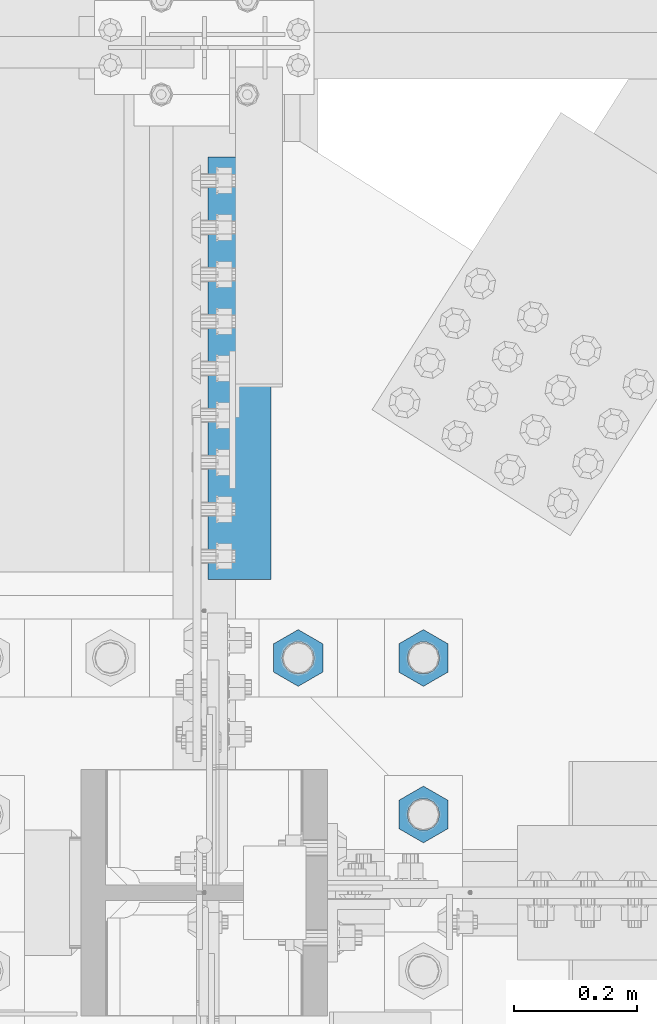
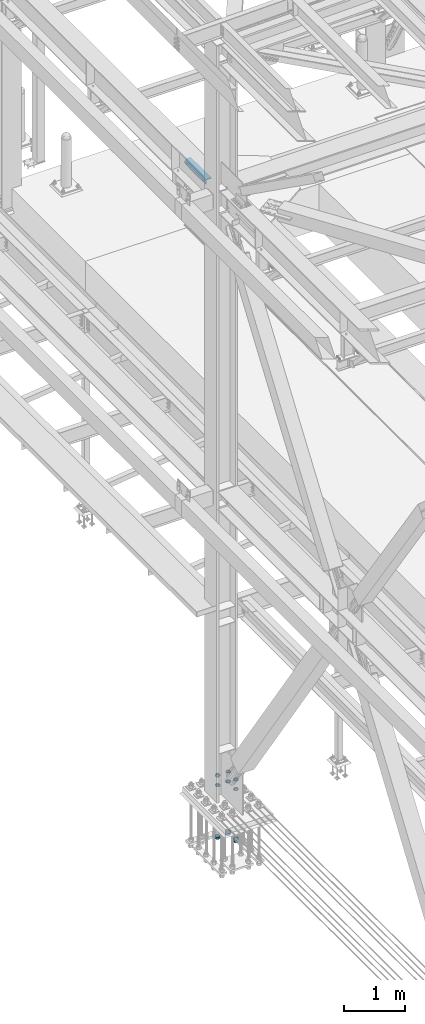
# One storey, part 2388 of 3843: 12 beams, 2 elements without a shape of their own.
"""IFC2X3 building model written with IfcOpenShell, lengths in millimetres."""

from ifc_helpers import new_model, si_unit, frame, origin_with_axes, place, context, subcontext, project, spatial, faceted_brep, material, type_object, element, aggregate, save


model = new_model("IFC2X3")

# Units and contexts
model_context = context("Model", 3, precision=1e-05, world=origin_with_axes())
body_context = subcontext(model_context, "Body", "Model", "MODEL_VIEW")
ifc_project = project(units=[si_unit("LENGTHUNIT", "METRE", prefix="MILLI"), si_unit("AREAUNIT", "SQUARE_METRE"), si_unit("VOLUMEUNIT", "CUBIC_METRE"), si_unit("MASSUNIT", "GRAM", prefix="KILO"), si_unit("TIMEUNIT", "SECOND"), si_unit("PLANEANGLEUNIT", "RADIAN"), si_unit("SOLIDANGLEUNIT", "STERADIAN"), si_unit("THERMODYNAMICTEMPERATUREUNIT", "DEGREE_CELSIUS"), si_unit("LUMINOUSINTENSITYUNIT", "LUMEN")], contexts=[model_context])

# Site, building, storey
site_placement = place(None, origin_with_axes())
site = spatial("IfcSite", under=ifc_project, at=site_placement, CompositionType="ELEMENT")
building_placement = place(site_placement, origin_with_axes())
building = spatial("IfcBuilding", under=site, at=building_placement, Name="Undefined", CompositionType="ELEMENT")
storey_placement = place(building_placement, origin_with_axes())
storey = spatial("IfcBuildingStorey", under=building, at=storey_placement, Name="Undefined", CompositionType="ELEMENT", Elevation=0.0)

# Assembly, beams
assembly_1_placement = place(storey_placement, origin_with_axes())
assembly_1 = element("IfcElementAssembly", 1, at=assembly_1_placement, inside=storey, Name="TEMPLATE", AssemblyPlace="NOTDEFINED", PredefinedType="RIGID_FRAME")
ifc_material = material(Name="STEEL/A572-50")
beam_type_1 = type_object("IfcBeamType", Name="2_HALF_NUT", PredefinedType="NOTDEFINED")
beam_1_placement = place(assembly_1_placement, frame((36931.6, 75755.5, 30060.9), z_axis=(1.0, 0.0, 0.0), x_axis=(0.0, 0.0, -1.0)))
beam_1 = element("IfcBeam", 2, at=beam_1_placement, type_object=beam_type_1, material=ifc_material, Name="NUT", ObjectType="2_HALF_NUT", context=body_context, shape_type="Brep", body=[
    faceted_brep([(0.0, -46.0369987487793, 0.0), (0.0, -23.0184993743896, -39.869213104248), (25.4000000000015, -23.0184993743896, -39.869213104248), (25.4000000000015, -46.0369987487793, 0.0), (0.0, 23.0184993743896, -39.869213104248), (25.4000000000015, 23.0184993743896, -39.869213104248), (0.0, 46.0369987487793, 0.0), (25.4000000000015, 46.0369987487793, 0.0), (0.0, 23.0184993743896, 39.869213104248), (25.4000000000015, 23.0184993743896, 39.869213104248), (0.0, -23.0184993743896, 39.869213104248), (25.4000000000015, -23.0184993743896, 39.869213104248), (0.0, 0.0, 26.1940002441406), (0.0, 11.3650617044477, 23.5999013092805), (25.4000000000015, 11.3650617044477, 23.5999013092805), (25.4000000000015, 0.0, 26.1940002441406), (0.0, 20.4791109456419, 16.3316083006721), (25.4000000000015, 20.4791109456419, 16.3316083006721), (0.0, 25.5370200498292, 5.82867859874386), (25.4000000000015, 25.5370200498292, 5.82867859874386), (0.0, 25.5370200498292, -5.82867859874386), (25.4000000000015, 25.5370200498292, -5.82867859874386), (0.0, 20.4791109456419, -16.3316083006721), (25.4000000000015, 20.4791109456419, -16.3316083006721), (0.0, 11.3650617044477, -23.5999013092805), (25.4000000000015, 11.3650617044477, -23.5999013092805), (0.0, 0.0, -26.1940002441406), (25.4000000000015, 0.0, -26.1940002441406), (0.0, -11.3650617044477, -23.5999013092805), (25.4000000000015, -11.3650617044477, -23.5999013092805), (0.0, -20.4791109456419, -16.3316083006721), (25.4000000000015, -20.4791109456419, -16.3316083006721), (0.0, -25.5370200498292, -5.82867859874386), (25.4000000000015, -25.5370200498292, -5.82867859874386), (0.0, -25.5370200498292, 5.82867859874386), (25.4000000000015, -25.5370200498292, 5.82867859874386), (0.0, -20.4791109456419, 16.3316083006721), (25.4000000000015, -20.4791109456419, 16.3316083006721), (0.0, -11.3650617044477, 23.5999013092805), (25.4000000000015, -11.3650617044477, 23.5999013092805)], [[[0, 1, 2, 3]], [[1, 4, 5, 2]], [[4, 6, 7, 5]], [[6, 8, 9, 7]], [[8, 10, 11, 9]], [[10, 0, 3, 11]], [[12, 13, 14, 15]], [[13, 16, 17, 14]], [[16, 18, 19, 17]], [[18, 20, 21, 19]], [[20, 22, 23, 21]], [[22, 24, 25, 23]], [[24, 26, 27, 25]], [[26, 28, 29, 27]], [[28, 30, 31, 29]], [[30, 32, 33, 31]], [[32, 34, 35, 33]], [[34, 36, 37, 35]], [[36, 38, 39, 37]], [[38, 12, 15, 39]], [[5, 7, 9, 11, 3, 2], [17, 19, 21, 23, 25, 27, 29, 31, 33, 35, 37, 39, 15, 14]], [[10, 8, 6, 4, 1, 0], [38, 36, 34, 32, 30, 28, 26, 24, 22, 20, 18, 16, 13, 12]]]),
])
beam_2_placement = place(assembly_1_placement, frame((36931.6, 76009.5, 30060.9), z_axis=(1.0, 0.0, 0.0), x_axis=(0.0, 0.0, -1.0)))
beam_2 = element("IfcBeam", 3, at=beam_2_placement, type_object=beam_type_1, material=ifc_material, Name="NUT", ObjectType="2_HALF_NUT", context=body_context, shape_type="Brep", body=[
    faceted_brep([(0.0, -46.0369987487793, 0.0), (0.0, -23.0184993743896, -39.869213104248), (25.4000000000015, -23.0184993743896, -39.869213104248), (25.4000000000015, -46.0369987487793, 0.0), (0.0, 23.0184993743896, -39.869213104248), (25.4000000000015, 23.0184993743896, -39.869213104248), (0.0, 46.0369987487793, 0.0), (25.4000000000015, 46.0369987487793, 0.0), (0.0, 23.0184993743896, 39.869213104248), (25.4000000000015, 23.0184993743896, 39.869213104248), (0.0, -23.0184993743896, 39.869213104248), (25.4000000000015, -23.0184993743896, 39.869213104248), (0.0, 0.0, 26.1940002441406), (0.0, 11.3650617044477, 23.5999013092805), (25.4000000000015, 11.3650617044477, 23.5999013092805), (25.4000000000015, 0.0, 26.1940002441406), (0.0, 20.4791109456419, 16.3316083006721), (25.4000000000015, 20.4791109456419, 16.3316083006721), (0.0, 25.5370200498292, 5.82867859874386), (25.4000000000015, 25.5370200498292, 5.82867859874386), (0.0, 25.5370200498292, -5.82867859874386), (25.4000000000015, 25.5370200498292, -5.82867859874386), (0.0, 20.4791109456419, -16.3316083006721), (25.4000000000015, 20.4791109456419, -16.3316083006721), (0.0, 11.3650617044477, -23.5999013092805), (25.4000000000015, 11.3650617044477, -23.5999013092805), (0.0, 0.0, -26.1940002441406), (25.4000000000015, 0.0, -26.1940002441406), (0.0, -11.3650617044477, -23.5999013092805), (25.4000000000015, -11.3650617044477, -23.5999013092805), (0.0, -20.4791109456419, -16.3316083006721), (25.4000000000015, -20.4791109456419, -16.3316083006721), (0.0, -25.5370200498292, -5.82867859874386), (25.4000000000015, -25.5370200498292, -5.82867859874386), (0.0, -25.5370200498292, 5.82867859874386), (25.4000000000015, -25.5370200498292, 5.82867859874386), (0.0, -20.4791109456419, 16.3316083006721), (25.4000000000015, -20.4791109456419, 16.3316083006721), (0.0, -11.3650617044477, 23.5999013092805), (25.4000000000015, -11.3650617044477, 23.5999013092805)], [[[0, 1, 2, 3]], [[1, 4, 5, 2]], [[4, 6, 7, 5]], [[6, 8, 9, 7]], [[8, 10, 11, 9]], [[10, 0, 3, 11]], [[12, 13, 14, 15]], [[13, 16, 17, 14]], [[16, 18, 19, 17]], [[18, 20, 21, 19]], [[20, 22, 23, 21]], [[22, 24, 25, 23]], [[24, 26, 27, 25]], [[26, 28, 29, 27]], [[28, 30, 31, 29]], [[30, 32, 33, 31]], [[32, 34, 35, 33]], [[34, 36, 37, 35]], [[36, 38, 39, 37]], [[38, 12, 15, 39]], [[5, 7, 9, 11, 3, 2], [17, 19, 21, 23, 25, 27, 29, 31, 33, 35, 37, 39, 15, 14]], [[10, 8, 6, 4, 1, 0], [38, 36, 34, 32, 30, 28, 26, 24, 22, 20, 18, 16, 13, 12]]]),
])
beam_3_placement = place(assembly_1_placement, frame((36728.4, 76009.5, 30060.9), z_axis=(1.0, 0.0, 0.0), x_axis=(0.0, 0.0, -1.0)))
beam_3 = element("IfcBeam", 4, at=beam_3_placement, type_object=beam_type_1, material=ifc_material, Name="NUT", ObjectType="2_HALF_NUT", context=body_context, shape_type="Brep", body=[
    faceted_brep([(0.0, -46.0369987487793, 0.0), (0.0, -23.0184993743896, -39.869213104248), (25.4000000000015, -23.0184993743896, -39.869213104248), (25.4000000000015, -46.0369987487793, 0.0), (0.0, 23.0184993743896, -39.869213104248), (25.4000000000015, 23.0184993743896, -39.869213104248), (0.0, 46.0369987487793, 0.0), (25.4000000000015, 46.0369987487793, 0.0), (0.0, 23.0184993743896, 39.869213104248), (25.4000000000015, 23.0184993743896, 39.869213104248), (0.0, -23.0184993743896, 39.869213104248), (25.4000000000015, -23.0184993743896, 39.869213104248), (0.0, 0.0, 26.1940002441406), (0.0, 11.3650617044477, 23.5999013092805), (25.4000000000015, 11.3650617044477, 23.5999013092805), (25.4000000000015, 0.0, 26.1940002441406), (0.0, 20.4791109456419, 16.3316083006721), (25.4000000000015, 20.4791109456419, 16.3316083006721), (0.0, 25.5370200498292, 5.82867859874386), (25.4000000000015, 25.5370200498292, 5.82867859874386), (0.0, 25.5370200498292, -5.82867859874386), (25.4000000000015, 25.5370200498292, -5.82867859874386), (0.0, 20.4791109456419, -16.3316083006721), (25.4000000000015, 20.4791109456419, -16.3316083006721), (0.0, 11.3650617044477, -23.5999013092805), (25.4000000000015, 11.3650617044477, -23.5999013092805), (0.0, 0.0, -26.1940002441406), (25.4000000000015, 0.0, -26.1940002441406), (0.0, -11.3650617044477, -23.5999013092805), (25.4000000000015, -11.3650617044477, -23.5999013092805), (0.0, -20.4791109456419, -16.3316083006721), (25.4000000000015, -20.4791109456419, -16.3316083006721), (0.0, -25.5370200498292, -5.82867859874386), (25.4000000000015, -25.5370200498292, -5.82867859874386), (0.0, -25.5370200498292, 5.82867859874386), (25.4000000000015, -25.5370200498292, 5.82867859874386), (0.0, -20.4791109456419, 16.3316083006721), (25.4000000000015, -20.4791109456419, 16.3316083006721), (0.0, -11.3650617044477, 23.5999013092805), (25.4000000000015, -11.3650617044477, 23.5999013092805)], [[[0, 1, 2, 3]], [[1, 4, 5, 2]], [[4, 6, 7, 5]], [[6, 8, 9, 7]], [[8, 10, 11, 9]], [[10, 0, 3, 11]], [[12, 13, 14, 15]], [[13, 16, 17, 14]], [[16, 18, 19, 17]], [[18, 20, 21, 19]], [[20, 22, 23, 21]], [[22, 24, 25, 23]], [[24, 26, 27, 25]], [[26, 28, 29, 27]], [[28, 30, 31, 29]], [[30, 32, 33, 31]], [[32, 34, 35, 33]], [[34, 36, 37, 35]], [[36, 38, 39, 37]], [[38, 12, 15, 39]], [[5, 7, 9, 11, 3, 2], [17, 19, 21, 23, 25, 27, 29, 31, 33, 35, 37, 39, 15, 14]], [[10, 8, 6, 4, 1, 0], [38, 36, 34, 32, 30, 28, 26, 24, 22, 20, 18, 16, 13, 12]]]),
])
beam_4_placement = place(assembly_1_placement, frame((36931.6, 75755.5, 29070.3), z_axis=(-1.0, 0.0, 0.0), x_axis=(0.0, 0.0, -1.0)))
beam_4 = element("IfcBeam", 5, at=beam_4_placement, type_object=beam_type_1, material=ifc_material, Name="NUT", ObjectType="2_HALF_NUT", context=body_context, shape_type="Brep", body=[
    faceted_brep([(0.0, -46.0369987487793, 0.0), (0.0, -23.0184993743896, -39.869213104248), (25.4000000000015, -23.0184993743896, -39.869213104248), (25.4000000000015, -46.0369987487793, 0.0), (0.0, 23.0184993743896, -39.869213104248), (25.4000000000015, 23.0184993743896, -39.869213104248), (0.0, 46.0369987487793, 0.0), (25.4000000000015, 46.0369987487793, 0.0), (0.0, 23.0184993743896, 39.869213104248), (25.4000000000015, 23.0184993743896, 39.869213104248), (0.0, -23.0184993743896, 39.869213104248), (25.4000000000015, -23.0184993743896, 39.869213104248), (0.0, 0.0, 26.1940002441406), (0.0, 11.3650617044477, 23.5999013092805), (25.4000000000015, 11.3650617044477, 23.5999013092805), (25.4000000000015, 0.0, 26.1940002441406), (0.0, 20.4791109456419, 16.3316083006721), (25.4000000000015, 20.4791109456419, 16.3316083006721), (0.0, 25.5370200498292, 5.82867859874386), (25.4000000000015, 25.5370200498292, 5.82867859874386), (0.0, 25.5370200498292, -5.82867859874386), (25.4000000000015, 25.5370200498292, -5.82867859874386), (0.0, 20.4791109456419, -16.3316083006721), (25.4000000000015, 20.4791109456419, -16.3316083006721), (0.0, 11.3650617044477, -23.5999013092805), (25.4000000000015, 11.3650617044477, -23.5999013092805), (0.0, 0.0, -26.1940002441406), (25.4000000000015, 0.0, -26.1940002441406), (0.0, -11.3650617044477, -23.5999013092805), (25.4000000000015, -11.3650617044477, -23.5999013092805), (0.0, -20.4791109456419, -16.3316083006721), (25.4000000000015, -20.4791109456419, -16.3316083006721), (0.0, -25.5370200498292, -5.82867859874386), (25.4000000000015, -25.5370200498292, -5.82867859874386), (0.0, -25.5370200498292, 5.82867859874386), (25.4000000000015, -25.5370200498292, 5.82867859874386), (0.0, -20.4791109456419, 16.3316083006721), (25.4000000000015, -20.4791109456419, 16.3316083006721), (0.0, -11.3650617044477, 23.5999013092805), (25.4000000000015, -11.3650617044477, 23.5999013092805)], [[[0, 1, 2, 3]], [[1, 4, 5, 2]], [[4, 6, 7, 5]], [[6, 8, 9, 7]], [[8, 10, 11, 9]], [[10, 0, 3, 11]], [[12, 13, 14, 15]], [[13, 16, 17, 14]], [[16, 18, 19, 17]], [[18, 20, 21, 19]], [[20, 22, 23, 21]], [[22, 24, 25, 23]], [[24, 26, 27, 25]], [[26, 28, 29, 27]], [[28, 30, 31, 29]], [[30, 32, 33, 31]], [[32, 34, 35, 33]], [[34, 36, 37, 35]], [[36, 38, 39, 37]], [[38, 12, 15, 39]], [[5, 7, 9, 11, 3, 2], [17, 19, 21, 23, 25, 27, 29, 31, 33, 35, 37, 39, 15, 14]], [[10, 8, 6, 4, 1, 0], [38, 36, 34, 32, 30, 28, 26, 24, 22, 20, 18, 16, 13, 12]]]),
])
beam_5_placement = place(assembly_1_placement, frame((36931.6, 76009.5, 30257.75), z_axis=(1.0, 0.0, 0.0), x_axis=(0.0, 0.0, -1.0)))
beam_5 = element("IfcBeam", 6, at=beam_5_placement, type_object=beam_type_1, material=ifc_material, Name="NUT", ObjectType="2_HALF_NUT", context=body_context, shape_type="Brep", body=[
    faceted_brep([(0.0, -46.0369987487793, 0.0), (0.0, -23.0184993743896, -39.869213104248), (25.4000000000015, -23.0184993743896, -39.869213104248), (25.4000000000015, -46.0369987487793, 0.0), (0.0, 23.0184993743896, -39.869213104248), (25.4000000000015, 23.0184993743896, -39.869213104248), (0.0, 46.0369987487793, 0.0), (25.4000000000015, 46.0369987487793, 0.0), (0.0, 23.0184993743896, 39.869213104248), (25.4000000000015, 23.0184993743896, 39.869213104248), (0.0, -23.0184993743896, 39.869213104248), (25.4000000000015, -23.0184993743896, 39.869213104248), (0.0, 0.0, 26.1940002441406), (0.0, 11.3650617044477, 23.5999013092805), (25.4000000000015, 11.3650617044477, 23.5999013092805), (25.4000000000015, 0.0, 26.1940002441406), (0.0, 20.4791109456419, 16.3316083006721), (25.4000000000015, 20.4791109456419, 16.3316083006721), (0.0, 25.5370200498292, 5.82867859874386), (25.4000000000015, 25.5370200498292, 5.82867859874386), (0.0, 25.5370200498292, -5.82867859874386), (25.4000000000015, 25.5370200498292, -5.82867859874386), (0.0, 20.4791109456419, -16.3316083006721), (25.4000000000015, 20.4791109456419, -16.3316083006721), (0.0, 11.3650617044477, -23.5999013092805), (25.4000000000015, 11.3650617044477, -23.5999013092805), (0.0, 0.0, -26.1940002441406), (25.4000000000015, 0.0, -26.1940002441406), (0.0, -11.3650617044477, -23.5999013092805), (25.4000000000015, -11.3650617044477, -23.5999013092805), (0.0, -20.4791109456419, -16.3316083006721), (25.4000000000015, -20.4791109456419, -16.3316083006721), (0.0, -25.5370200498292, -5.82867859874386), (25.4000000000015, -25.5370200498292, -5.82867859874386), (0.0, -25.5370200498292, 5.82867859874386), (25.4000000000015, -25.5370200498292, 5.82867859874386), (0.0, -20.4791109456419, 16.3316083006721), (25.4000000000015, -20.4791109456419, 16.3316083006721), (0.0, -11.3650617044477, 23.5999013092805), (25.4000000000015, -11.3650617044477, 23.5999013092805)], [[[0, 1, 2, 3]], [[1, 4, 5, 2]], [[4, 6, 7, 5]], [[6, 8, 9, 7]], [[8, 10, 11, 9]], [[10, 0, 3, 11]], [[12, 13, 14, 15]], [[13, 16, 17, 14]], [[16, 18, 19, 17]], [[18, 20, 21, 19]], [[20, 22, 23, 21]], [[22, 24, 25, 23]], [[24, 26, 27, 25]], [[26, 28, 29, 27]], [[28, 30, 31, 29]], [[30, 32, 33, 31]], [[32, 34, 35, 33]], [[34, 36, 37, 35]], [[36, 38, 39, 37]], [[38, 12, 15, 39]], [[5, 7, 9, 11, 3, 2], [17, 19, 21, 23, 25, 27, 29, 31, 33, 35, 37, 39, 15, 14]], [[10, 8, 6, 4, 1, 0], [38, 36, 34, 32, 30, 28, 26, 24, 22, 20, 18, 16, 13, 12]]]),
])
beam_6_placement = place(assembly_1_placement, frame((36728.4, 76009.5, 30257.75), z_axis=(1.0, 0.0, 0.0), x_axis=(0.0, 0.0, -1.0)))
beam_6 = element("IfcBeam", 7, at=beam_6_placement, type_object=beam_type_1, material=ifc_material, Name="NUT", ObjectType="2_HALF_NUT", context=body_context, shape_type="Brep", body=[
    faceted_brep([(0.0, -46.0369987487793, 0.0), (0.0, -23.0184993743896, -39.869213104248), (25.4000000000015, -23.0184993743896, -39.869213104248), (25.4000000000015, -46.0369987487793, 0.0), (0.0, 23.0184993743896, -39.869213104248), (25.4000000000015, 23.0184993743896, -39.869213104248), (0.0, 46.0369987487793, 0.0), (25.4000000000015, 46.0369987487793, 0.0), (0.0, 23.0184993743896, 39.869213104248), (25.4000000000015, 23.0184993743896, 39.869213104248), (0.0, -23.0184993743896, 39.869213104248), (25.4000000000015, -23.0184993743896, 39.869213104248), (0.0, 0.0, 26.1940002441406), (0.0, 11.3650617044477, 23.5999013092805), (25.4000000000015, 11.3650617044477, 23.5999013092805), (25.4000000000015, 0.0, 26.1940002441406), (0.0, 20.4791109456419, 16.3316083006721), (25.4000000000015, 20.4791109456419, 16.3316083006721), (0.0, 25.5370200498292, 5.82867859874386), (25.4000000000015, 25.5370200498292, 5.82867859874386), (0.0, 25.5370200498292, -5.82867859874386), (25.4000000000015, 25.5370200498292, -5.82867859874386), (0.0, 20.4791109456419, -16.3316083006721), (25.4000000000015, 20.4791109456419, -16.3316083006721), (0.0, 11.3650617044477, -23.5999013092805), (25.4000000000015, 11.3650617044477, -23.5999013092805), (0.0, 0.0, -26.1940002441406), (25.4000000000015, 0.0, -26.1940002441406), (0.0, -11.3650617044477, -23.5999013092805), (25.4000000000015, -11.3650617044477, -23.5999013092805), (0.0, -20.4791109456419, -16.3316083006721), (25.4000000000015, -20.4791109456419, -16.3316083006721), (0.0, -25.5370200498292, -5.82867859874386), (25.4000000000015, -25.5370200498292, -5.82867859874386), (0.0, -25.5370200498292, 5.82867859874386), (25.4000000000015, -25.5370200498292, 5.82867859874386), (0.0, -20.4791109456419, 16.3316083006721), (25.4000000000015, -20.4791109456419, 16.3316083006721), (0.0, -11.3650617044477, 23.5999013092805), (25.4000000000015, -11.3650617044477, 23.5999013092805)], [[[0, 1, 2, 3]], [[1, 4, 5, 2]], [[4, 6, 7, 5]], [[6, 8, 9, 7]], [[8, 10, 11, 9]], [[10, 0, 3, 11]], [[12, 13, 14, 15]], [[13, 16, 17, 14]], [[16, 18, 19, 17]], [[18, 20, 21, 19]], [[20, 22, 23, 21]], [[22, 24, 25, 23]], [[24, 26, 27, 25]], [[26, 28, 29, 27]], [[28, 30, 31, 29]], [[30, 32, 33, 31]], [[32, 34, 35, 33]], [[34, 36, 37, 35]], [[36, 38, 39, 37]], [[38, 12, 15, 39]], [[5, 7, 9, 11, 3, 2], [17, 19, 21, 23, 25, 27, 29, 31, 33, 35, 37, 39, 15, 14]], [[10, 8, 6, 4, 1, 0], [38, 36, 34, 32, 30, 28, 26, 24, 22, 20, 18, 16, 13, 12]]]),
])
beam_7_placement = place(assembly_1_placement, frame((36931.6, 75755.5, 30257.75), z_axis=(1.0, 0.0, 0.0), x_axis=(0.0, 0.0, -1.0)))
beam_7 = element("IfcBeam", 8, at=beam_7_placement, type_object=beam_type_1, material=ifc_material, Name="NUT", ObjectType="2_HALF_NUT", context=body_context, shape_type="Brep", body=[
    faceted_brep([(0.0, -46.0369987487793, 0.0), (0.0, -23.0184993743896, -39.869213104248), (25.4000000000015, -23.0184993743896, -39.869213104248), (25.4000000000015, -46.0369987487793, 0.0), (0.0, 23.0184993743896, -39.869213104248), (25.4000000000015, 23.0184993743896, -39.869213104248), (0.0, 46.0369987487793, 0.0), (25.4000000000015, 46.0369987487793, 0.0), (0.0, 23.0184993743896, 39.869213104248), (25.4000000000015, 23.0184993743896, 39.869213104248), (0.0, -23.0184993743896, 39.869213104248), (25.4000000000015, -23.0184993743896, 39.869213104248), (0.0, 0.0, 26.1940002441406), (0.0, 11.3650617044477, 23.5999013092805), (25.4000000000015, 11.3650617044477, 23.5999013092805), (25.4000000000015, 0.0, 26.1940002441406), (0.0, 20.4791109456419, 16.3316083006721), (25.4000000000015, 20.4791109456419, 16.3316083006721), (0.0, 25.5370200498292, 5.82867859874386), (25.4000000000015, 25.5370200498292, 5.82867859874386), (0.0, 25.5370200498292, -5.82867859874386), (25.4000000000015, 25.5370200498292, -5.82867859874386), (0.0, 20.4791109456419, -16.3316083006721), (25.4000000000015, 20.4791109456419, -16.3316083006721), (0.0, 11.3650617044477, -23.5999013092805), (25.4000000000015, 11.3650617044477, -23.5999013092805), (0.0, 0.0, -26.1940002441406), (25.4000000000015, 0.0, -26.1940002441406), (0.0, -11.3650617044477, -23.5999013092805), (25.4000000000015, -11.3650617044477, -23.5999013092805), (0.0, -20.4791109456419, -16.3316083006721), (25.4000000000015, -20.4791109456419, -16.3316083006721), (0.0, -25.5370200498292, -5.82867859874386), (25.4000000000015, -25.5370200498292, -5.82867859874386), (0.0, -25.5370200498292, 5.82867859874386), (25.4000000000015, -25.5370200498292, 5.82867859874386), (0.0, -20.4791109456419, 16.3316083006721), (25.4000000000015, -20.4791109456419, 16.3316083006721), (0.0, -11.3650617044477, 23.5999013092805), (25.4000000000015, -11.3650617044477, 23.5999013092805)], [[[0, 1, 2, 3]], [[1, 4, 5, 2]], [[4, 6, 7, 5]], [[6, 8, 9, 7]], [[8, 10, 11, 9]], [[10, 0, 3, 11]], [[12, 13, 14, 15]], [[13, 16, 17, 14]], [[16, 18, 19, 17]], [[18, 20, 21, 19]], [[20, 22, 23, 21]], [[22, 24, 25, 23]], [[24, 26, 27, 25]], [[26, 28, 29, 27]], [[28, 30, 31, 29]], [[30, 32, 33, 31]], [[32, 34, 35, 33]], [[34, 36, 37, 35]], [[36, 38, 39, 37]], [[38, 12, 15, 39]], [[5, 7, 9, 11, 3, 2], [17, 19, 21, 23, 25, 27, 29, 31, 33, 35, 37, 39, 15, 14]], [[10, 8, 6, 4, 1, 0], [38, 36, 34, 32, 30, 28, 26, 24, 22, 20, 18, 16, 13, 12]]]),
])
beam_8_placement = place(assembly_1_placement, frame((36931.6, 76009.5, 29057.6), z_axis=(1.0, 0.0, 0.0), x_axis=(0.0, 0.0, -1.0)))
beam_8 = element("IfcBeam", 9, at=beam_8_placement, type_object=beam_type_1, material=ifc_material, Name="NUT", ObjectType="2_HALF_NUT", context=body_context, shape_type="Brep", body=[
    faceted_brep([(0.0, -46.0369987487793, 0.0), (0.0, -23.0184993743896, -39.869213104248), (25.4000000000015, -23.0184993743896, -39.869213104248), (25.4000000000015, -46.0369987487793, 0.0), (0.0, 23.0184993743896, -39.869213104248), (25.4000000000015, 23.0184993743896, -39.869213104248), (0.0, 46.0369987487793, 0.0), (25.4000000000015, 46.0369987487793, 0.0), (0.0, 23.0184993743896, 39.869213104248), (25.4000000000015, 23.0184993743896, 39.869213104248), (0.0, -23.0184993743896, 39.869213104248), (25.4000000000015, -23.0184993743896, 39.869213104248), (0.0, 0.0, 26.1940002441406), (0.0, 11.3650617044477, 23.5999013092805), (25.4000000000015, 11.3650617044477, 23.5999013092805), (25.4000000000015, 0.0, 26.1940002441406), (0.0, 20.4791109456419, 16.3316083006721), (25.4000000000015, 20.4791109456419, 16.3316083006721), (0.0, 25.5370200498292, 5.82867859874386), (25.4000000000015, 25.5370200498292, 5.82867859874386), (0.0, 25.5370200498292, -5.82867859874386), (25.4000000000015, 25.5370200498292, -5.82867859874386), (0.0, 20.4791109456419, -16.3316083006721), (25.4000000000015, 20.4791109456419, -16.3316083006721), (0.0, 11.3650617044477, -23.5999013092805), (25.4000000000015, 11.3650617044477, -23.5999013092805), (0.0, 0.0, -26.1940002441406), (25.4000000000015, 0.0, -26.1940002441406), (0.0, -11.3650617044477, -23.5999013092805), (25.4000000000015, -11.3650617044477, -23.5999013092805), (0.0, -20.4791109456419, -16.3316083006721), (25.4000000000015, -20.4791109456419, -16.3316083006721), (0.0, -25.5370200498292, -5.82867859874386), (25.4000000000015, -25.5370200498292, -5.82867859874386), (0.0, -25.5370200498292, 5.82867859874386), (25.4000000000015, -25.5370200498292, 5.82867859874386), (0.0, -20.4791109456419, 16.3316083006721), (25.4000000000015, -20.4791109456419, 16.3316083006721), (0.0, -11.3650617044477, 23.5999013092805), (25.4000000000015, -11.3650617044477, 23.5999013092805)], [[[0, 1, 2, 3]], [[1, 4, 5, 2]], [[4, 6, 7, 5]], [[6, 8, 9, 7]], [[8, 10, 11, 9]], [[10, 0, 3, 11]], [[12, 13, 14, 15]], [[13, 16, 17, 14]], [[16, 18, 19, 17]], [[18, 20, 21, 19]], [[20, 22, 23, 21]], [[22, 24, 25, 23]], [[24, 26, 27, 25]], [[26, 28, 29, 27]], [[28, 30, 31, 29]], [[30, 32, 33, 31]], [[32, 34, 35, 33]], [[34, 36, 37, 35]], [[36, 38, 39, 37]], [[38, 12, 15, 39]], [[5, 7, 9, 11, 3, 2], [17, 19, 21, 23, 25, 27, 29, 31, 33, 35, 37, 39, 15, 14]], [[10, 8, 6, 4, 1, 0], [38, 36, 34, 32, 30, 28, 26, 24, 22, 20, 18, 16, 13, 12]]]),
])
beam_type_2 = type_object("IfcBeamType", Name="2_HEAVY_HEX_NUT", PredefinedType="NOTDEFINED")
beam_9_placement = place(assembly_1_placement, frame((36931.6, 75755.5, 29044.9), z_axis=(-1.0, 0.0, 0.0), x_axis=(0.0, 0.0, -1.0)))
beam_9 = element("IfcBeam", 10, at=beam_9_placement, type_object=beam_type_2, material=ifc_material, Name="NUT", ObjectType="2_HEAVY_HEX_NUT", context=body_context, shape_type="Brep", body=[
    faceted_brep([(0.0, -46.0369987487793, 0.0), (0.0, -23.0184993743896, -39.869213104248), (50.7999999999993, -23.0184993743896, -39.869213104248), (50.7999999999993, -46.0369987487793, 0.0), (0.0, 23.0184993743896, -39.869213104248), (50.7999999999993, 23.0184993743896, -39.869213104248), (0.0, 46.0369987487793, 0.0), (50.7999999999993, 46.0369987487793, 0.0), (0.0, 23.0184993743896, 39.869213104248), (50.7999999999993, 23.0184993743896, 39.869213104248), (0.0, -23.0184993743896, 39.869213104248), (50.7999999999993, -23.0184993743896, 39.869213104248), (0.0, 0.0, 26.1940002441406), (0.0, 11.3650617044477, 23.5999013092805), (50.7999999999993, 11.3650617044477, 23.5999013092805), (50.7999999999993, 0.0, 26.1940002441406), (0.0, 20.4791109456419, 16.3316083006721), (50.7999999999993, 20.4791109456419, 16.3316083006721), (0.0, 25.5370200498292, 5.82867859874386), (50.7999999999993, 25.5370200498292, 5.82867859874386), (0.0, 25.5370200498292, -5.82867859874386), (50.7999999999993, 25.5370200498292, -5.82867859874386), (0.0, 20.4791109456419, -16.3316083006721), (50.7999999999993, 20.4791109456419, -16.3316083006721), (0.0, 11.3650617044477, -23.5999013092805), (50.7999999999993, 11.3650617044477, -23.5999013092805), (0.0, 0.0, -26.1940002441406), (50.7999999999993, 0.0, -26.1940002441406), (0.0, -11.3650617044477, -23.5999013092805), (50.7999999999993, -11.3650617044477, -23.5999013092805), (0.0, -20.4791109456419, -16.3316083006721), (50.7999999999993, -20.4791109456419, -16.3316083006721), (0.0, -25.5370200498292, -5.82867859874386), (50.7999999999993, -25.5370200498292, -5.82867859874386), (0.0, -25.5370200498292, 5.82867859874386), (50.7999999999993, -25.5370200498292, 5.82867859874386), (0.0, -20.4791109456419, 16.3316083006721), (50.7999999999993, -20.4791109456419, 16.3316083006721), (0.0, -11.3650617044477, 23.5999013092805), (50.7999999999993, -11.3650617044477, 23.5999013092805)], [[[0, 1, 2, 3]], [[1, 4, 5, 2]], [[4, 6, 7, 5]], [[6, 8, 9, 7]], [[8, 10, 11, 9]], [[10, 0, 3, 11]], [[12, 13, 14, 15]], [[13, 16, 17, 14]], [[16, 18, 19, 17]], [[18, 20, 21, 19]], [[20, 22, 23, 21]], [[22, 24, 25, 23]], [[24, 26, 27, 25]], [[26, 28, 29, 27]], [[28, 30, 31, 29]], [[30, 32, 33, 31]], [[32, 34, 35, 33]], [[34, 36, 37, 35]], [[36, 38, 39, 37]], [[38, 12, 15, 39]], [[5, 7, 9, 11, 3, 2], [17, 19, 21, 23, 25, 27, 29, 31, 33, 35, 37, 39, 15, 14]], [[10, 8, 6, 4, 1, 0], [38, 36, 34, 32, 30, 28, 26, 24, 22, 20, 18, 16, 13, 12]]]),
])
beam_10_placement = place(assembly_1_placement, frame((36931.6, 76009.5, 29032.2), z_axis=(1.0, 0.0, 0.0), x_axis=(0.0, 0.0, -1.0)))
beam_10 = element("IfcBeam", 11, at=beam_10_placement, type_object=beam_type_2, material=ifc_material, Name="NUT", ObjectType="2_HEAVY_HEX_NUT", context=body_context, shape_type="Brep", body=[
    faceted_brep([(0.0, -46.0369987487793, 0.0), (0.0, -23.0184993743896, -39.869213104248), (50.7999999999993, -23.0184993743896, -39.869213104248), (50.7999999999993, -46.0369987487793, 0.0), (0.0, 23.0184993743896, -39.869213104248), (50.7999999999993, 23.0184993743896, -39.869213104248), (0.0, 46.0369987487793, 0.0), (50.7999999999993, 46.0369987487793, 0.0), (0.0, 23.0184993743896, 39.869213104248), (50.7999999999993, 23.0184993743896, 39.869213104248), (0.0, -23.0184993743896, 39.869213104248), (50.7999999999993, -23.0184993743896, 39.869213104248), (0.0, 0.0, 26.1940002441406), (0.0, 11.3650617044477, 23.5999013092805), (50.7999999999993, 11.3650617044477, 23.5999013092805), (50.7999999999993, 0.0, 26.1940002441406), (0.0, 20.4791109456419, 16.3316083006721), (50.7999999999993, 20.4791109456419, 16.3316083006721), (0.0, 25.5370200498292, 5.82867859874386), (50.7999999999993, 25.5370200498292, 5.82867859874386), (0.0, 25.5370200498292, -5.82867859874386), (50.7999999999993, 25.5370200498292, -5.82867859874386), (0.0, 20.4791109456419, -16.3316083006721), (50.7999999999993, 20.4791109456419, -16.3316083006721), (0.0, 11.3650617044477, -23.5999013092805), (50.7999999999993, 11.3650617044477, -23.5999013092805), (0.0, 0.0, -26.1940002441406), (50.7999999999993, 0.0, -26.1940002441406), (0.0, -11.3650617044477, -23.5999013092805), (50.7999999999993, -11.3650617044477, -23.5999013092805), (0.0, -20.4791109456419, -16.3316083006721), (50.7999999999993, -20.4791109456419, -16.3316083006721), (0.0, -25.5370200498292, -5.82867859874386), (50.7999999999993, -25.5370200498292, -5.82867859874386), (0.0, -25.5370200498292, 5.82867859874386), (50.7999999999993, -25.5370200498292, 5.82867859874386), (0.0, -20.4791109456419, 16.3316083006721), (50.7999999999993, -20.4791109456419, 16.3316083006721), (0.0, -11.3650617044477, 23.5999013092805), (50.7999999999993, -11.3650617044477, 23.5999013092805)], [[[0, 1, 2, 3]], [[1, 4, 5, 2]], [[4, 6, 7, 5]], [[6, 8, 9, 7]], [[8, 10, 11, 9]], [[10, 0, 3, 11]], [[12, 13, 14, 15]], [[13, 16, 17, 14]], [[16, 18, 19, 17]], [[18, 20, 21, 19]], [[20, 22, 23, 21]], [[22, 24, 25, 23]], [[24, 26, 27, 25]], [[26, 28, 29, 27]], [[28, 30, 31, 29]], [[30, 32, 33, 31]], [[32, 34, 35, 33]], [[34, 36, 37, 35]], [[36, 38, 39, 37]], [[38, 12, 15, 39]], [[5, 7, 9, 11, 3, 2], [17, 19, 21, 23, 25, 27, 29, 31, 33, 35, 37, 39, 15, 14]], [[10, 8, 6, 4, 1, 0], [38, 36, 34, 32, 30, 28, 26, 24, 22, 20, 18, 16, 13, 12]]]),
])
beam_11_placement = place(assembly_1_placement, frame((36728.4, 76009.5, 29032.2), z_axis=(1.0, 0.0, 0.0), x_axis=(0.0, 0.0, -1.0)))
beam_11 = element("IfcBeam", 12, at=beam_11_placement, type_object=beam_type_2, material=ifc_material, Name="NUT", ObjectType="2_HEAVY_HEX_NUT", context=body_context, shape_type="Brep", body=[
    faceted_brep([(0.0, -46.0369987487793, 0.0), (0.0, -23.0184993743896, -39.869213104248), (50.7999999999993, -23.0184993743896, -39.869213104248), (50.7999999999993, -46.0369987487793, 0.0), (0.0, 23.0184993743896, -39.869213104248), (50.7999999999993, 23.0184993743896, -39.869213104248), (0.0, 46.0369987487793, 0.0), (50.7999999999993, 46.0369987487793, 0.0), (0.0, 23.0184993743896, 39.869213104248), (50.7999999999993, 23.0184993743896, 39.869213104248), (0.0, -23.0184993743896, 39.869213104248), (50.7999999999993, -23.0184993743896, 39.869213104248), (0.0, 0.0, 26.1940002441406), (0.0, 11.3650617044477, 23.5999013092805), (50.7999999999993, 11.3650617044477, 23.5999013092805), (50.7999999999993, 0.0, 26.1940002441406), (0.0, 20.4791109456419, 16.3316083006721), (50.7999999999993, 20.4791109456419, 16.3316083006721), (0.0, 25.5370200498292, 5.82867859874386), (50.7999999999993, 25.5370200498292, 5.82867859874386), (0.0, 25.5370200498292, -5.82867859874386), (50.7999999999993, 25.5370200498292, -5.82867859874386), (0.0, 20.4791109456419, -16.3316083006721), (50.7999999999993, 20.4791109456419, -16.3316083006721), (0.0, 11.3650617044477, -23.5999013092805), (50.7999999999993, 11.3650617044477, -23.5999013092805), (0.0, 0.0, -26.1940002441406), (50.7999999999993, 0.0, -26.1940002441406), (0.0, -11.3650617044477, -23.5999013092805), (50.7999999999993, -11.3650617044477, -23.5999013092805), (0.0, -20.4791109456419, -16.3316083006721), (50.7999999999993, -20.4791109456419, -16.3316083006721), (0.0, -25.5370200498292, -5.82867859874386), (50.7999999999993, -25.5370200498292, -5.82867859874386), (0.0, -25.5370200498292, 5.82867859874386), (50.7999999999993, -25.5370200498292, 5.82867859874386), (0.0, -20.4791109456419, 16.3316083006721), (50.7999999999993, -20.4791109456419, 16.3316083006721), (0.0, -11.3650617044477, 23.5999013092805), (50.7999999999993, -11.3650617044477, 23.5999013092805)], [[[0, 1, 2, 3]], [[1, 4, 5, 2]], [[4, 6, 7, 5]], [[6, 8, 9, 7]], [[8, 10, 11, 9]], [[10, 0, 3, 11]], [[12, 13, 14, 15]], [[13, 16, 17, 14]], [[16, 18, 19, 17]], [[18, 20, 21, 19]], [[20, 22, 23, 21]], [[22, 24, 25, 23]], [[24, 26, 27, 25]], [[26, 28, 29, 27]], [[28, 30, 31, 29]], [[30, 32, 33, 31]], [[32, 34, 35, 33]], [[34, 36, 37, 35]], [[36, 38, 39, 37]], [[38, 12, 15, 39]], [[5, 7, 9, 11, 3, 2], [17, 19, 21, 23, 25, 27, 29, 31, 33, 35, 37, 39, 15, 14]], [[10, 8, 6, 4, 1, 0], [38, 36, 34, 32, 30, 28, 26, 24, 22, 20, 18, 16, 13, 12]]]),
])
aggregate(assembly_1, [beam_1, beam_2, beam_3, beam_9, beam_4, beam_5, beam_6, beam_7, beam_10, beam_8, beam_11])

# Assembly, beam
assembly_2_placement = place(storey_placement, origin_with_axes())
assembly_2 = element("IfcElementAssembly", 13, at=assembly_2_placement, inside=storey, Name="PLATE", AssemblyPlace="NOTDEFINED", PredefinedType="RIGID_FRAME")
beam_type_3 = type_object("IfcBeamType", Name="L4X4X1/2", PredefinedType="NOTDEFINED")
beam_12_placement = place(assembly_2_placement, frame((36633.1499999982, 76136.5, 42167.1766278841), z_axis=(1.0, 0.0, 0.0), x_axis=(0.0, 1.0, 0.0)))
beam_12 = element("IfcBeam", 14, at=beam_12_placement, type_object=beam_type_3, material=ifc_material, Name="ANGLE", ObjectType="L4X4X1/2", context=body_context, shape_type="Brep", body=[
    faceted_brep([(0.0, 50.8000000000029, -50.8000000000029), (0.0, 50.8000000000029, 50.8000000000029), (685.800000000003, 50.8000000000029, 50.8000000000029), (685.800000000003, 50.8000000000029, -50.8000000000029), (0.0, 38.0999999999985, 50.8000000000029), (685.800000000003, 38.0999999999985, 50.8000000000029), (0.0, 38.0999999999985, -38.0999999999985), (685.800000000003, 38.0999999999985, -38.1000000000058), (0.0, -50.8000000000029, -38.1000000000058), (685.800000000003, -50.8000000000029, -38.1000000000058), (0.0, -50.8000000000029, -50.8000000000029), (685.800000000003, -50.8000000000029, -50.8000000000029)], [[[0, 1, 2, 3]], [[1, 4, 5, 2]], [[4, 6, 7, 5]], [[6, 8, 9, 7]], [[8, 10, 11, 9]], [[10, 0, 3, 11]], [[5, 7, 9, 11, 3, 2]], [[10, 8, 6, 4, 1, 0]]]),
])
aggregate(assembly_2, [beam_12])

save(model, "model.ifc")
